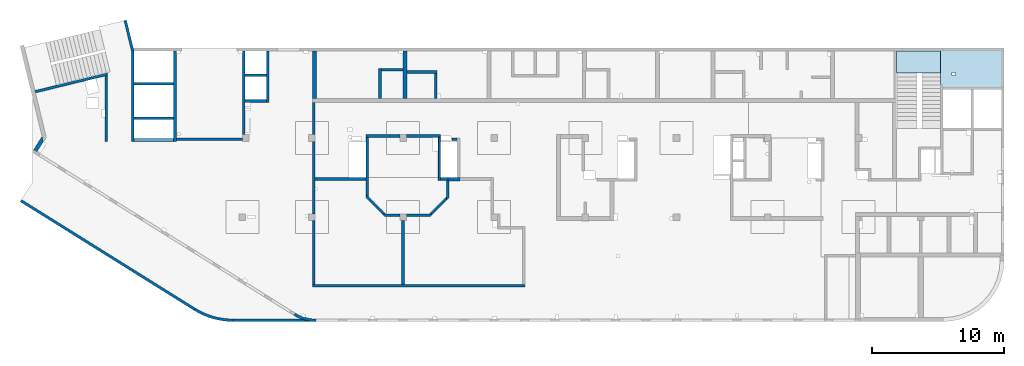
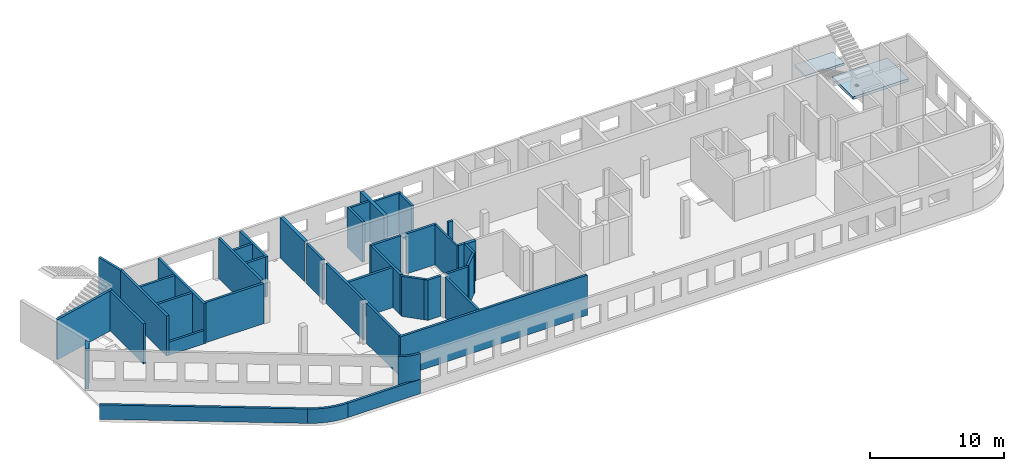
# One storey, part 3 of 10: 42 walls, 2 slabs.
"""IFC4 building model written with IfcOpenShell, lengths in millimetres."""

from ifc_helpers import new_model, entity, si_unit, converted_unit, derived_unit, direction, frame, origin, place, context, subcontext, project, spatial, indexed_curve, outline, extrude, material, type_object, element, save


model = new_model("IFC4")

# Units and contexts
model_context = context("Model", 3, precision=0.01, world=origin(), true_north=direction((6.12303176911189e-17, 1.0)))
plan_context = context("Plan", 3, precision=0.01, world=origin(), true_north=direction((6.12303176911189e-17, 1.0)))
body_context = subcontext(model_context, "Body", "Model", "MODEL_VIEW")
ifc_project = project(units=[si_unit("LENGTHUNIT", "METRE", prefix="MILLI"), si_unit("AREAUNIT", "SQUARE_METRE"), si_unit("VOLUMEUNIT", "CUBIC_METRE"), converted_unit("PLANEANGLEUNIT", "DEGREE", entity("IfcRatioMeasure", 0.0174532925199433), si_unit("PLANEANGLEUNIT", "RADIAN"), dimensions=[0, 0, 0, 0, 0, 0, 0]), si_unit("MASSUNIT", "GRAM", prefix="KILO"), derived_unit("MASSDENSITYUNIT", [(si_unit("MASSUNIT", "GRAM", prefix="KILO"), 1), (si_unit("LENGTHUNIT", "METRE"), -3)]), derived_unit("MOMENTOFINERTIAUNIT", [(si_unit("LENGTHUNIT", "METRE"), 4)]), si_unit("TIMEUNIT", "SECOND"), si_unit("FREQUENCYUNIT", "HERTZ"), si_unit("THERMODYNAMICTEMPERATUREUNIT", "DEGREE_CELSIUS"), derived_unit("THERMALTRANSMITTANCEUNIT", [(si_unit("MASSUNIT", "GRAM", prefix="KILO"), 1), (si_unit("THERMODYNAMICTEMPERATUREUNIT", "KELVIN"), -1), (si_unit("TIMEUNIT", "SECOND"), -3)]), derived_unit("VOLUMETRICFLOWRATEUNIT", [(si_unit("LENGTHUNIT", "METRE"), 3), (si_unit("TIMEUNIT", "SECOND"), -1)]), derived_unit("MASSFLOWRATEUNIT", [(si_unit("MASSUNIT", "GRAM", prefix="KILO"), 1), (si_unit("TIMEUNIT", "SECOND"), -1)]), derived_unit("ROTATIONALFREQUENCYUNIT", [(si_unit("TIMEUNIT", "SECOND"), -1)]), si_unit("ELECTRICCURRENTUNIT", "AMPERE"), si_unit("ELECTRICVOLTAGEUNIT", "VOLT"), si_unit("POWERUNIT", "WATT"), si_unit("FORCEUNIT", "NEWTON", prefix="KILO"), si_unit("ILLUMINANCEUNIT", "LUX"), si_unit("LUMINOUSFLUXUNIT", "LUMEN"), si_unit("LUMINOUSINTENSITYUNIT", "CANDELA"), derived_unit("USERDEFINED", [(si_unit("MASSUNIT", "GRAM", prefix="KILO"), -1), (si_unit("LENGTHUNIT", "METRE"), -2), (si_unit("TIMEUNIT", "SECOND"), 3), (si_unit("LUMINOUSFLUXUNIT", "LUMEN"), 1)]), derived_unit("LINEARVELOCITYUNIT", [(si_unit("LENGTHUNIT", "METRE"), 1), (si_unit("TIMEUNIT", "SECOND"), -1)]), si_unit("PRESSUREUNIT", "PASCAL"), derived_unit("USERDEFINED", [(si_unit("LENGTHUNIT", "METRE"), -2), (si_unit("MASSUNIT", "GRAM", prefix="KILO"), 1), (si_unit("TIMEUNIT", "SECOND"), -2)]), derived_unit("LINEARFORCEUNIT", [(si_unit("MASSUNIT", "GRAM", prefix="KILO"), 1), (si_unit("LENGTHUNIT", "METRE"), 1), (si_unit("TIMEUNIT", "SECOND"), -2), (si_unit("LENGTHUNIT", "METRE"), -1)]), derived_unit("PLANARFORCEUNIT", [(si_unit("MASSUNIT", "GRAM", prefix="KILO"), 1), (si_unit("LENGTHUNIT", "METRE"), 1), (si_unit("TIMEUNIT", "SECOND"), -2), (si_unit("LENGTHUNIT", "METRE"), -2)])], contexts=[model_context, plan_context])

# Site, building, storey
site_placement = place(None, origin())
site = spatial("IfcSite", under=ifc_project, at=site_placement, CompositionType="ELEMENT")
building_placement = place(site_placement, origin())
building = spatial("IfcBuilding", under=site, at=building_placement, CompositionType="ELEMENT")
storey_placement = place(building_placement, frame((0.0, 0.0, 4200.0)))
storey = spatial("IfcBuildingStorey", under=building, at=storey_placement, Name="02", CompositionType="ELEMENT", Elevation=4200.0)

# Slabs
ifc_material = material()
slab_type_1 = type_object("IfcSlabType", Name=":ADSK_ 25_250", PredefinedType="FLOOR", material=ifc_material)
placement = place(storey_placement, origin())
element("IfcSlab", 1, at=placement, inside=storey, type_object=slab_type_1, material=ifc_material, Name=":ADSK_ 25_250", ObjectType=":ADSK_ 25_250", PredefinedType="FLOOR", context=body_context, shape_type="SweptSolid", body=[
    extrude(outline(indexed_curve([(-1590.00000000001, -2374.99999999999), (-1390.00000000001, -2374.99999999999), (1539.99999999999, -2375.0), (1540.0, -2175.00000000001), (1540.00000000001, 2225.00000000001), (1540.00000000001, 2425.0), (-1589.99999999999, 2425.00000000001), (-1589.99999999999, 2225.00000000001), (-1590.00000000001, -2374.99999999999)], self_intersect=False), holes=[indexed_curve([(234.999999999561, -1250.00000000008), (484.999999999556, -1250.00000000008), (484.999999999556, -1500.00000000009), (234.999999999561, -1500.00000000009), (234.999999999561, -1250.00000000008)], self_intersect=False)]), frame((71145.0, 18910.0, -670.0), z_axis=(0.0, 0.0, 1.0), x_axis=(0.0, -1.0, 0.0)), (0.0, 0.0, 1.0), 250.0),
])
slab_type_2 = type_object("IfcSlabType", Name=":ADSK_ 25_200", PredefinedType="FLOOR", material=ifc_material)
element("IfcSlab", 2, at=placement, inside=storey, type_object=slab_type_2, material=ifc_material, Name=":ADSK_ 25_200", ObjectType=":ADSK_ 25_200", PredefinedType="FLOOR", context=body_context, shape_type="SweptSolid", body=[
    extrude(outline(indexed_curve([(-835.000000000001, -1670.00000000001), (834.999999999999, -1670.00000000001), (834.999999999999, 1670.00000000002), (-835.000000000001, 1670.00000000002), (-835.000000000001, -1670.00000000001)], self_intersect=False)), frame((67100.0, 19465.0, 1920.0), z_axis=(0.0, 0.0, -1.0), x_axis=(0.0, 1.0, 0.0)), (0.0, 0.0, 1.0), 200.0),
])

# Walls
wall_type_1 = type_object("IfcWallType", Name=":ADSK_ 25_200", PredefinedType="STANDARD")
wall_1_placement = place(storey_placement, frame((21465.0, -100.0, 0.0)))
element("IfcWall", 3, at=wall_1_placement, inside=storey, type_object=wall_type_1, material=ifc_material, Name=":ADSK_ 25_200", ObjectType=":ADSK_ 25_200", PredefinedType="NOTDEFINED", context=body_context, shape_type="SweptSolid", body=[
    extrude(outline(indexed_curve([(-1669.73115912917, 370.165232796526), (-1517.43719360754, 282.663604846569), (-1360.57165411762, 203.64974942406), (-1199.60712853313, 133.361711099216), (-1035.02855371873, 72.0112462252115), (-867.331754563609, 19.7831849810763), (-697.021950212787, -23.1651254650805), (-524.612231996435, -56.7042949949421), (-350.622017642682, -80.733280352823), (-175.575486430924, -95.1796895580798), (-5.19776222063229e-11, -100.0), (8.66293703438714e-12, 100.0), (-164.508224209949, 104.513888503701), (-328.521400565226, 118.041970555164), (-491.545970938351, 140.54353665169), (-653.091352173305, 171.950873752934), (-812.671412377304, 212.169469046979), (-969.805933817563, 261.078294363871), (-1124.02205802084, 318.530170380726), (-1274.85570872706, 384.352209522432), (-1421.85298841496, 458.346336225141), (-1564.57154419729, 540.289882996944), (-1669.73115912917, 370.165232796526)], self_intersect=False)), origin(), (0.0, 0.0, 1.0), 3500.0),
])
wall_2_placement = place(storey_placement, frame((-865.41, 8952.8, -150.0), z_axis=(0.0, 0.0, 1.0), x_axis=(0.848052743777572, -0.529911826412028, 0.0)))
element("IfcWall", 4, at=wall_2_placement, inside=storey, type_object=wall_type_1, material=ifc_material, Name=":ADSK_ 25_200", ObjectType=":ADSK_ 25_200", PredefinedType="NOTDEFINED", context=body_context, shape_type="SweptSolid", body=[
    extrude(outline(indexed_curve([(15506.5810864381, 100.0), (-1.03210773261253e-12, 100.0), (-1.94577687295805e-12, -99.9999999999995), (15506.5810864381, -99.9999999999989), (15506.5810864381, 100.0)], self_intersect=False)), origin(), (0.0, 0.0, 1.0), 1310.0),
])
wall_3_placement = place(storey_placement, frame((12284.99, 735.68, -150.0)))
element("IfcWall", 5, at=wall_3_placement, inside=storey, type_object=wall_type_1, material=ifc_material, Name=":ADSK_ 25_200", ObjectType=":ADSK_ 25_200", PredefinedType="NOTDEFINED", context=body_context, shape_type="SweptSolid", body=[
    extrude(outline(indexed_curve([(2915.01250070512, -735.684570137693), (2613.5342675926, -727.260252967498), (2312.99598516675, -702.024663872808), (2014.33436437137, -660.056456568838), (1718.48026701357, -601.486436618048), (1426.35580447471, -526.497153738303), (1138.87146369442, -435.322332836042), (856.923269385443, -328.246145537743), (581.389991323978, -205.602324490218), (313.130405419884, -67.7731231902071), (52.9806171032711, 84.8118754146881), (-52.9806171032429, -84.811875414706), (216.800382689777, -243.0458441733), (494.991419313605, -385.977729561331), (780.725433216402, -513.162044700461), (1073.11185506481, -624.202384384319), (1371.2393814503, -718.752660585296), (1674.17881521919, -796.518181133935), (1980.98596157331, -857.256568208814), (2290.7045709151, -900.778513774291), (2602.36931926479, -926.948369611523), (2915.00881696042, -935.684570103768), (2915.01250070512, -735.684570137693)], self_intersect=False)), origin(), (0.0, 0.0, 1.0), 1310.0),
])
wall_4_placement = place(storey_placement, frame((15200.0, -100.0, -150.0)))
element("IfcWall", 6, at=wall_4_placement, inside=storey, type_object=wall_type_1, material=ifc_material, Name=":ADSK_ 25_200", ObjectType=":ADSK_ 25_200", PredefinedType="NOTDEFINED", context=body_context, shape_type="SweptSolid", body=[
    extrude(outline(indexed_curve([(6264.99815812798, 100.0), (-3.14842759861503e-13, 100.0), (3.14842759861503e-13, -100.0), (6264.99815812798, -100.0), (6264.99815812798, 100.0)], self_intersect=False)), origin(), (0.0, 0.0, 1.0), 1310.0),
])
wall_5_placement = place(storey_placement, frame((220.24, 17202.38, -150.0), z_axis=(0.0, 0.0, 1.0), x_axis=(0.971552058141474, 0.236826092990334, 0.0)))
element("IfcWall", 7, at=wall_5_placement, inside=storey, type_object=wall_type_1, material=ifc_material, Name=":ADSK_ 25_200", ObjectType=":ADSK_ 25_200", PredefinedType="NOTDEFINED", context=body_context, shape_type="SweptSolid", body=[
    extrude(outline(indexed_curve([(5615.84117734387, -100.0), (5664.5932933022, 99.9999999999997), (3.13016279562817e-13, 99.9999999999999), (3.4262592762957e-13, -100.0), (5409.98499256816, -100.000000000001), (5615.84117734387, -100.0)], self_intersect=False)), origin(), (0.0, 0.0, 1.0), 3650.0),
])
wall_6_placement = place(storey_placement, frame((5600.0, 18435.2, -150.0), z_axis=(0.0, 0.0, 1.0), x_axis=(0.0, -1.0, 0.0)))
element("IfcWall", 8, at=wall_6_placement, inside=storey, type_object=wall_type_1, material=ifc_material, Name=":ADSK_ 25_200", ObjectType=":ADSK_ 25_200", PredefinedType="NOTDEFINED", context=body_context, shape_type="SweptSolid", body=[
    extrude(outline(indexed_curve([(4985.20145861122, -100.0), (4985.20145861122, 99.9999999999997), (-1.66881927142981e-13, 100.0), (48.7521159583304, -99.9999999999999), (2585.20145861117, -100.0), (3145.20145861117, -100.0), (4985.20145861122, -100.0)], self_intersect=False)), origin(), (0.0, 0.0, 1.0), 3650.0),
])
wall_7_placement = place(storey_placement, frame((7033.44, 22609.75, -150.0), z_axis=(0.0, 0.0, 1.0), x_axis=(0.236826092990336, -0.971552058141474, 0.0)))
element("IfcWall", 9, at=wall_7_placement, inside=storey, type_object=wall_type_1, material=ifc_material, Name=":ADSK_ 25_200", ObjectType=":ADSK_ 25_200", PredefinedType="NOTDEFINED", context=body_context, shape_type="SweptSolid", body=[
    extrude(outline(indexed_curve([(2380.28371765133, -100.0), (2404.30804833155, 99.9999999999996), (2401.76043829435, 99.9999999999994), (2195.90425351863, 99.9999999999995), (9.13669140345519e-13, 99.9999999999997), (-9.13669140345519e-13, -99.9999999999997), (2380.28371765133, -100.0)], self_intersect=False)), origin(), (0.0, 0.0, 1.0), 3650.0),
])
wall_8_placement = place(storey_placement, frame((7600.0, 13450.0, -150.0), z_axis=(0.0, 0.0, 1.0), x_axis=(0.0, 1.0, 0.0)))
element("IfcWall", 10, at=wall_8_placement, inside=storey, type_object=wall_type_1, material=ifc_material, Name=":ADSK_ 25_200", ObjectType=":ADSK_ 25_200", PredefinedType="NOTDEFINED", context=body_context, shape_type="SweptSolid", body=[
    extrude(outline(indexed_curve([(6847.52486422501, -99.9999999999998), (6823.50053354478, 100.0), (2.00396858490402e-12, 100.0), (1.61765673692763e-13, -100.0), (200.0, -99.9999999999997), (1649.99999999998, -99.9999999999995), (1849.99999999998, -100.0), (4249.99999999998, -99.9999999999996), (4449.99999999998, -100.0), (6847.52486422501, -99.9999999999998)], self_intersect=False)), origin(), (0.0, 0.0, 1.0), 3650.0),
])
wall_9_placement = place(storey_placement, frame((10800.0, 20300.0, -150.0), z_axis=(0.0, 0.0, 1.0), x_axis=(0.0, -1.0, 0.0)))
element("IfcWall", 11, at=wall_9_placement, inside=storey, type_object=wall_type_1, material=ifc_material, Name=":ADSK_ 25_200", ObjectType=":ADSK_ 25_200", PredefinedType="NOTDEFINED", context=body_context, shape_type="SweptSolid", body=[
    extrude(outline(indexed_curve([(6849.99999999999, 99.9999999999989), (-1.58082792598304e-13, 99.9999999999989), (1.58082792598304e-13, -99.9999999999989), (6849.99999999999, -99.9999999999989), (6849.99999999999, 99.9999999999989)], self_intersect=False)), origin(), (0.0, 0.0, 1.0), 3650.0),
])
for number, where, name in (
    (12, (7700.0, 15200.0, -150.0), ":ADSK_ 25_200"),
    (13, (7700.0, 17800.0, -150.0), ":ADSK_ 25_200"),
):
    element("IfcWall", number, at=place(storey_placement, frame(where)), inside=storey, type_object=wall_type_1, material=ifc_material, Name=name, ObjectType=":ADSK_ 25_200", PredefinedType="NOTDEFINED", context=body_context, shape_type="SweptSolid", body=[
        extrude(outline(indexed_curve([(3000.0, 99.9999999999989), (-2.88764567812901e-13, 99.9999999999989), (2.88764567812901e-13, -99.9999999999989), (3000.0, -99.9999999999989), (3000.0, 99.9999999999989)], self_intersect=False)), origin(), (0.0, 0.0, 1.0), 3650.0),
    ])
wall_10_placement = place(storey_placement, frame((10900.0, 13600.0, -150.0)))
element("IfcWall", 14, at=wall_10_placement, inside=storey, type_object=wall_type_1, material=ifc_material, Name=":ADSK_ 25_200", ObjectType=":ADSK_ 25_200", PredefinedType="NOTDEFINED", context=body_context, shape_type="SweptSolid", body=[
    extrude(outline(indexed_curve([(4999.99999999999, 99.9999999999989), (-3.03202796203547e-13, 99.9999999999989), (3.03202796203547e-13, -99.9999999999989), (4999.99999999999, -99.9999999999989), (4999.99999999999, 99.9999999999989)], self_intersect=False)), origin(), (0.0, 0.0, 1.0), 3650.0),
])
wall_11_placement = place(storey_placement, frame((16000.0, 13950.0, -150.0), z_axis=(0.0, 0.0, 1.0), x_axis=(0.0, 1.0, 0.0)))
element("IfcWall", 15, at=wall_11_placement, inside=storey, type_object=wall_type_1, material=ifc_material, Name=":ADSK_ 25_200", ObjectType=":ADSK_ 25_200", PredefinedType="NOTDEFINED", context=body_context, shape_type="SweptSolid", body=[
    extrude(outline(indexed_curve([(6350.00000000003, 99.999999999999), (-1.71883671317202e-13, 99.9999999999989), (1.71883671317202e-13, -99.9999999999989), (6350.00000000003, -99.9999999999988), (6350.00000000003, 99.999999999999)], self_intersect=False)), origin(), (0.0, 0.0, 1.0), 3650.0),
])
wall_12_placement = place(storey_placement, frame((17825.0, 20300.0, -150.0), z_axis=(0.0, 0.0, 1.0), x_axis=(0.0, -1.0, 0.0)))
element("IfcWall", 16, at=wall_12_placement, inside=storey, type_object=wall_type_1, material=ifc_material, Name=":ADSK_ 25_200", ObjectType=":ADSK_ 25_200", PredefinedType="NOTDEFINED", context=body_context, shape_type="SweptSolid", body=[
    extrude(outline(indexed_curve([(3900.00000000024, 99.9999999999989), (-1.66594942968972e-13, 99.9999999999989), (1.66594942968972e-13, -99.9999999999989), (3900.00000000024, -99.9999999999989), (3900.00000000024, 99.9999999999989)], self_intersect=False)), origin(), (0.0, 0.0, 1.0), 3650.0),
])
wall_13_placement = place(storey_placement, frame((17725.0, 16500.0, -150.0), z_axis=(0.0, 0.0, 1.0), x_axis=(-1.0, 0.0, 0.0)))
element("IfcWall", 17, at=wall_13_placement, inside=storey, type_object=wall_type_1, material=ifc_material, Name=":ADSK_ 25_200", ObjectType=":ADSK_ 25_200", PredefinedType="NOTDEFINED", context=body_context, shape_type="SweptSolid", body=[
    extrude(outline(indexed_curve([(1624.99999999998, 99.9999999999982), (-3.5601111100221e-13, 99.9999999999989), (3.5601111100221e-13, -99.9999999999989), (1624.99999999998, -99.9999999999996), (1624.99999999998, 99.9999999999982)], self_intersect=False)), origin(), (0.0, 0.0, 1.0), 3650.0),
])
wall_14_placement = place(storey_placement, frame((17725.0, 18450.0, -150.0), z_axis=(0.0, 0.0, 1.0), x_axis=(-1.0, 0.0, 0.0)))
element("IfcWall", 18, at=wall_14_placement, inside=storey, type_object=wall_type_1, material=ifc_material, Name=":ADSK_ 25_200", ObjectType=":ADSK_ 25_200", PredefinedType="NOTDEFINED", context=body_context, shape_type="SweptSolid", body=[
    extrude(outline(indexed_curve([(1624.99999999999, 99.9999999999986), (-3.77156646455302e-13, 99.9999999999989), (3.77156646455302e-13, -99.9999999999989), (1624.99999999999, -99.9999999999993), (1624.99999999999, 99.9999999999986)], self_intersect=False)), origin(), (0.0, 0.0, 1.0), 3650.0),
])
wall_15_placement = place(storey_placement, frame((21320.0, 13950.0, -150.0), z_axis=(0.0, 0.0, 1.0), x_axis=(0.0, 1.0, 0.0)))
element("IfcWall", 19, at=wall_15_placement, inside=storey, type_object=wall_type_1, material=ifc_material, Name=":ADSK_ 25_200", ObjectType=":ADSK_ 25_200", PredefinedType="NOTDEFINED", context=body_context, shape_type="SweptSolid", body=[
    extrude(outline(indexed_curve([(2449.99999999979, 99.9999999999994), (-1.96664178427031e-13, 99.9999999999989), (1.96664178427031e-13, -99.9999999999989), (2449.99999999979, -99.9999999999984), (2449.99999999979, 99.9999999999994)], self_intersect=False)), origin(), (0.0, 0.0, 1.0), 3650.0),
])
wall_16_placement = place(storey_placement, frame((21220.0, 2500.0, -150.0)))
element("IfcWall", 20, at=wall_16_placement, inside=storey, type_object=wall_type_1, material=ifc_material, Name=":ADSK_ 25_200", ObjectType=":ADSK_ 25_200", PredefinedType="NOTDEFINED", context=body_context, shape_type="SweptSolid", body=[
    extrude(outline(indexed_curve([(16075.0, 100.0), (-3.24719987565055e-13, 100.0), (3.24719987565054e-13, -99.9999999999997), (16075.0, -99.9999999999998), (16075.0, 100.0)], self_intersect=False)), origin(), (0.0, 0.0, 1.0), 3650.0),
])
wall_17_placement = place(storey_placement, frame((28070.0, 2600.0, -150.0), z_axis=(0.0, 0.0, 1.0), x_axis=(0.0, 1.0, 0.0)))
element("IfcWall", 21, at=wall_17_placement, inside=storey, type_object=wall_type_1, material=ifc_material, Name=":ADSK_ 25_200", ObjectType=":ADSK_ 25_200", PredefinedType="NOTDEFINED", context=body_context, shape_type="SweptSolid", body=[
    extrude(outline(indexed_curve([(4850.00000000007, 99.9999999999987), (-1.75008828977514e-13, 99.9999999999989), (1.75008828977514e-13, -99.9999999999989), (4850.00000000007, -99.9999999999991), (4850.00000000007, 99.9999999999987)], self_intersect=False)), origin(), (0.0, 0.0, 1.0), 3650.0),
])
wall_18_placement = place(storey_placement, frame((21320.0, 13450.0, -150.0), z_axis=(0.0, 0.0, 1.0), x_axis=(0.0, -1.0, 0.0)))
element("IfcWall", 22, at=wall_18_placement, inside=storey, type_object=wall_type_1, material=ifc_material, Name=":ADSK_ 25_200", ObjectType=":ADSK_ 25_200", PredefinedType="NOTDEFINED", context=body_context, shape_type="SweptSolid", body=[
    extrude(outline(indexed_curve([(5500.0, 99.9999999999989), (-1.57507946079764e-13, 99.9999999999989), (1.57507946079764e-13, -99.9999999999989), (5500.0, -99.9999999999989), (5500.0, 99.9999999999989)], self_intersect=False)), origin(), (0.0, 0.0, 1.0), 3650.0),
])
wall_19_placement = place(storey_placement, frame((21320.0, 7450.0, -150.0), z_axis=(0.0, 0.0, 1.0), x_axis=(0.0, -1.0, 0.0)))
element("IfcWall", 23, at=wall_19_placement, inside=storey, type_object=wall_type_1, material=ifc_material, Name=":ADSK_ 25_200", ObjectType=":ADSK_ 25_200", PredefinedType="NOTDEFINED", context=body_context, shape_type="SweptSolid", body=[
    extrude(outline(indexed_curve([(4850.00000000007, 99.9999999999989), (-1.78617258440967e-13, 99.9999999999989), (1.78617258440967e-13, -99.9999999999989), (4850.00000000007, -99.9999999999989), (4850.00000000007, 99.9999999999989)], self_intersect=False)), origin(), (0.0, 0.0, 1.0), 3650.0),
])
wall_20_placement = place(storey_placement, frame((32170.0, 13600.0, -150.0), z_axis=(0.0, 0.0, 1.0), x_axis=(-1.0, 0.0, 0.0)))
element("IfcWall", 24, at=wall_20_placement, inside=storey, type_object=wall_type_1, material=ifc_material, Name=":ADSK_ 25_200", ObjectType=":ADSK_ 25_200", PredefinedType="NOTDEFINED", context=body_context, shape_type="SweptSolid", body=[
    extrude(outline(indexed_curve([(399.999999999991, 99.9999999999982), (-3.60955709766133e-13, 99.9999999999989), (3.60955709766133e-13, -99.9999999999989), (399.999999999992, -99.9999999999996), (399.999999999991, 99.9999999999982)], self_intersect=False)), origin(), (0.0, 0.0, 1.0), 3650.0),
])
wall_21_placement = place(storey_placement, frame((31460.0, 10490.0, -150.0), z_axis=(0.0, 0.0, 1.0), x_axis=(0.0, -1.0, 0.0)))
element("IfcWall", 25, at=wall_21_placement, inside=storey, type_object=wall_type_1, material=ifc_material, Name=":ADSK_ 25_200", ObjectType=":ADSK_ 25_200", PredefinedType="NOTDEFINED", context=body_context, shape_type="SweptSolid", body=[
    extrude(outline(indexed_curve([(1517.84271247461, -100.000000000004), (1317.84271247462, 99.9999999999959), (65.0000000000382, 99.9999999999968), (65.0000000000372, -2.07407185169571e-12), (-4.33146851719343e-12, 4.33146851719371e-12), (-1.02514551324105e-12, -100.000000000003), (1235.0, -100.000000000004), (1517.84271247461, -100.000000000004)], self_intersect=False)), origin(), (0.0, 0.0, 1.0), 3650.0),
])
wall_22_placement = place(storey_placement, frame((28320.0, 7850.0, -150.0)))
element("IfcWall", 26, at=wall_22_placement, inside=storey, type_object=wall_type_1, material=ifc_material, Name=":ADSK_ 25_200", ObjectType=":ADSK_ 25_200", PredefinedType="NOTDEFINED", context=body_context, shape_type="SweptSolid", body=[
    extrude(outline(indexed_curve([(1817.84271247461, -99.9999999999999), (2017.84271247462, 99.9999999999996), (1735.0, 99.9999999999998), (-3.02005468313109e-13, 100.0), (3.02005468313109e-13, -100.0), (1817.84271247461, -99.9999999999999)], self_intersect=False)), origin(), (0.0, 0.0, 1.0), 3650.0),
])
wall_23_placement = place(storey_placement, frame((27820.0, 7850.0, -150.0), z_axis=(0.0, 0.0, 1.0), x_axis=(-1.0, 0.0, 0.0)))
element("IfcWall", 27, at=wall_23_placement, inside=storey, type_object=wall_type_1, material=ifc_material, Name=":ADSK_ 25_200", ObjectType=":ADSK_ 25_200", PredefinedType="NOTDEFINED", context=body_context, shape_type="SweptSolid", body=[
    extrude(outline(indexed_curve([(1347.84271247462, -99.9999999999998), (1147.84271247462, 100.0), (-4.9488612922406e-13, 100.0), (4.9488612922406e-13, -100.0), (1065.0, -100.0), (1347.84271247462, -99.9999999999998)], self_intersect=False)), origin(), (0.0, 0.0, 1.0), 3650.0),
])
wall_24_placement = place(storey_placement, frame((27820.0, 13850.0, -150.0), z_axis=(0.0, 0.0, 1.0), x_axis=(-1.0, 0.0, 0.0)))
element("IfcWall", 28, at=wall_24_placement, inside=storey, type_object=wall_type_1, material=ifc_material, Name=":ADSK_ 25_200", ObjectType=":ADSK_ 25_200", PredefinedType="NOTDEFINED", context=body_context, shape_type="SweptSolid", body=[
    extrude(outline(indexed_curve([(2570.00000000001, 99.9999999999988), (-3.32131638983616e-13, 99.9999999999989), (3.32131638983616e-13, -99.9999999999989), (2570.00000000001, -99.9999999999991), (2570.00000000001, 99.9999999999988)], self_intersect=False)), origin(), (0.0, 0.0, 1.0), 3650.0),
])
wall_25_placement = place(storey_placement, frame((25350.0, 13750.0, -150.0), z_axis=(0.0, 0.0, 1.0), x_axis=(0.0, -1.0, 0.0)))
element("IfcWall", 29, at=wall_25_placement, inside=storey, type_object=wall_type_1, material=ifc_material, Name=":ADSK_ 25_200", ObjectType=":ADSK_ 25_200", PredefinedType="NOTDEFINED", context=body_context, shape_type="SweptSolid", body=[
    extrude(outline(indexed_curve([(4295.0, -100.000000000003), (4495.00000000001, 99.9999999999989), (0.0, 99.9999999999989), (0.0, -100.000000000003), (3060.00000000004, -100.000000000003), (3260.00000000004, -100.000000000003), (4295.0, -100.000000000003)], self_intersect=False)), origin(), (0.0, 0.0, 1.0), 3650.0),
])
wall_26_placement = place(storey_placement, frame((28320.0, 13850.0, -150.0)))
element("IfcWall", 30, at=wall_26_placement, inside=storey, type_object=wall_type_1, material=ifc_material, Name=":ADSK_ 25_200", ObjectType=":ADSK_ 25_200", PredefinedType="NOTDEFINED", context=body_context, shape_type="SweptSolid", body=[
    extrude(outline(indexed_curve([(2580.0, 99.9999999999998), (-3.67626630400485e-13, 99.9999999999989), (3.67626630400485e-13, -99.9999999999989), (2580.0, -99.9999999999981), (2580.0, 99.9999999999998)], self_intersect=False)), origin(), (0.0, 0.0, 1.0), 3650.0),
])
wall_27_placement = place(storey_placement, frame((31460.0, 10590.0, -150.0), z_axis=(0.0, 0.0, 1.0), x_axis=(-1.0, 0.0, 0.0)))
element("IfcWall", 31, at=wall_27_placement, inside=storey, type_object=wall_type_1, material=ifc_material, Name=":ADSK_ 25_200", ObjectType=":ADSK_ 25_200", PredefinedType="NOTDEFINED", context=body_context, shape_type="SweptSolid", body=[
    extrude(outline(indexed_curve([(559.999999999966, 99.9999999999986), (-1.64731358047439e-12, 99.9999999999989), (1.64731358047439e-12, -99.9999999999989), (559.99999999997, -99.9999999999992), (559.999999999966, 99.9999999999986)], self_intersect=False)), origin(), (0.0, 0.0, 1.0), 3650.0),
])
wall_28_placement = place(storey_placement, frame((26684.29, 7879.29, -150.0), z_axis=(0.0, 0.0, 1.0), x_axis=(-0.707106781186546, 0.707106781186549, 0.0)))
element("IfcWall", 32, at=wall_28_placement, inside=storey, type_object=wall_type_1, material=ifc_material, Name=":ADSK_ 25_200", ObjectType=":ADSK_ 25_200", PredefinedType="NOTDEFINED", context=body_context, shape_type="SweptSolid", body=[
    extrude(outline(indexed_curve([(2128.39141137151, -100.000000000002), (1928.39141137151, 99.9999999999984), (200.000000000001, 99.9999999999979), (-1.32820421328006e-12, -100.000000000002), (1845.54869889689, -100.000000000002), (2128.39141137151, -100.000000000002)], self_intersect=False)), origin(), (0.0, 0.0, 1.0), 3650.0),
])
wall_29_placement = place(storey_placement, frame((25250.0, 10590.0, -150.0), z_axis=(0.0, 0.0, 1.0), x_axis=(-1.0, 0.0, 0.0)))
element("IfcWall", 33, at=wall_29_placement, inside=storey, type_object=wall_type_1, material=ifc_material, Name=":ADSK_ 25_200", ObjectType=":ADSK_ 25_200", PredefinedType="NOTDEFINED", context=body_context, shape_type="SweptSolid", body=[
    extrude(outline(indexed_curve([(3830.0, 100.000000000001), (-3.36454200178105e-13, 100.000000000001), (3.36454200178105e-13, -100.000000000001), (3830.0, -100.000000000001), (3830.0, 100.000000000001)], self_intersect=False)), origin(), (0.0, 0.0, 1.0), 3650.0),
])
wall_30_placement = place(storey_placement, frame((30125.71, 7879.29, -150.0), z_axis=(0.0, 0.0, 1.0), x_axis=(0.707106781186548, 0.707106781186547, 0.0)))
element("IfcWall", 34, at=wall_30_placement, inside=storey, type_object=wall_type_1, material=ifc_material, Name=":ADSK_ 25_200", ObjectType=":ADSK_ 25_200", PredefinedType="NOTDEFINED", context=body_context, shape_type="SweptSolid", body=[
    extrude(outline(indexed_curve([(1645.54869889691, -100.000000000003), (1845.5486988969, 99.9999999999981), (6.42952358020921e-13, 99.9999999999982), (200.000000000002, -100.000000000003), (1645.54869889691, -100.000000000003)], self_intersect=False)), origin(), (0.0, 0.0, 1.0), 3650.0),
])
wall_31_placement = place(storey_placement, frame((7700.0, 13550.0, -150.0)))
element("IfcWall", 35, at=wall_31_placement, inside=storey, type_object=wall_type_1, material=ifc_material, Name=":ADSK_ 25_200", ObjectType=":ADSK_ 25_200", PredefinedType="NOTDEFINED", context=body_context, shape_type="SweptSolid", body=[
    extrude(outline(indexed_curve([(3000.0, 99.9999999999989), (-2.88764567812901e-13, 99.9999999999989), (2.88764567812901e-13, -99.9999999999989), (3000.0, -99.9999999999989), (3000.0, 99.9999999999989)], self_intersect=False)), origin(), (0.0, 0.0, 1.0), 1200.0),
])
wall_32_placement = place(storey_placement, frame((26320.0, 16700.0, -150.0), z_axis=(0.0, 0.0, 1.0), x_axis=(0.0, 1.0, 0.0)))
element("IfcWall", 36, at=wall_32_placement, inside=storey, type_object=wall_type_1, material=ifc_material, Name=":ADSK_ 25_200", ObjectType=":ADSK_ 25_200", PredefinedType="NOTDEFINED", context=body_context, shape_type="SweptSolid", body=[
    extrude(outline(indexed_curve([(2280.0007736439, 99.9999999999993), (-2.08243601256231e-13, 99.9999999999989), (2.08243601256231e-13, -99.9999999999989), (2280.0007736439, -99.9999999999985), (2280.0007736439, 99.9999999999993)], self_intersect=False)), origin(), (0.0, 0.0, 1.0), 3650.0),
])
wall_33_placement = place(storey_placement, frame((26420.0, 18880.0, -150.0)))
element("IfcWall", 37, at=wall_33_placement, inside=storey, type_object=wall_type_1, material=ifc_material, Name=":ADSK_ 25_200", ObjectType=":ADSK_ 25_200", PredefinedType="NOTDEFINED", context=body_context, shape_type="SweptSolid", body=[
    extrude(outline(indexed_curve([(1650.00026855482, 99.9999999999989), (-2.62513200739495e-13, 99.9999999999989), (2.62513200739495e-13, -99.9999999999989), (1650.00026855482, -99.9999999999989), (1650.00026855482, 99.9999999999989)], self_intersect=False)), origin(), (0.0, 0.0, 1.0), 3650.0),
])
wall_34_placement = place(storey_placement, frame((28370.0, 18700.0, -150.0)))
element("IfcWall", 38, at=wall_34_placement, inside=storey, type_object=wall_type_1, material=ifc_material, Name=":ADSK_ 25_200", ObjectType=":ADSK_ 25_200", PredefinedType="NOTDEFINED", context=body_context, shape_type="SweptSolid", body=[
    extrude(outline(indexed_curve([(2279.99973144517, 99.9999999999995), (-3.12365558397263e-13, 99.9999999999989), (3.12365558397263e-13, -99.9999999999989), (2279.99973144517, -99.9999999999983), (2279.99973144517, 99.9999999999995)], self_intersect=False)), origin(), (0.0, 0.0, 1.0), 3650.0),
])
wall_35_placement = place(storey_placement, frame((30550.0, 18600.0, -150.0), z_axis=(0.0, 0.0, 1.0), x_axis=(0.0, -1.0, 0.0)))
element("IfcWall", 39, at=wall_35_placement, inside=storey, type_object=wall_type_1, material=ifc_material, Name=":ADSK_ 25_200", ObjectType=":ADSK_ 25_200", PredefinedType="NOTDEFINED", context=body_context, shape_type="SweptSolid", body=[
    extrude(outline(indexed_curve([(1900.0007736439, 99.9999999999989), (-2.27971934394871e-13, 99.9999999999989), (2.27971934394871e-13, -99.9999999999989), (1900.0007736439, -99.9999999999989), (1900.0007736439, 99.9999999999989)], self_intersect=False)), origin(), (0.0, 0.0, 1.0), 3650.0),
])
wall_type_2 = type_object("IfcWallType", Name=":ADSK_ 25_300", PredefinedType="STANDARD")
wall_36_placement = place(storey_placement, frame((233.4, 12729.37, -150.0), z_axis=(0.0, 0.0, 1.0), x_axis=(0.529911826412026, 0.848052743777573, 0.0)))
element("IfcWall", 40, at=wall_36_placement, inside=storey, type_object=wall_type_2, material=ifc_material, Name=":ADSK_ 25_300", ObjectType=":ADSK_ 25_300", PredefinedType="NOTDEFINED", context=body_context, shape_type="SweptSolid", body=[
    extrude(outline(indexed_curve([(896.727593512352, -150.000000000001), (1189.49773437786, 149.999999999999), (2.36031194589259e-12, 149.999999999999), (-7.1063155360207e-13, -150.000000000001), (896.727593512352, -150.000000000001)], self_intersect=False)), origin(), (0.0, 0.0, 1.0), 3650.0),
])
wall_37_placement = place(storey_placement, frame((21370.0, 16700.0, -150.0), z_axis=(0.0, 0.0, 1.0), x_axis=(0.0, 1.0, 0.0)))
element("IfcWall", 41, at=wall_37_placement, inside=storey, type_object=wall_type_2, material=ifc_material, Name=":ADSK_ 25_300", ObjectType=":ADSK_ 25_300", PredefinedType="NOTDEFINED", context=body_context, shape_type="SweptSolid", body=[
    extrude(outline(indexed_curve([(3600.00000000024, 150.0), (-3.27232685993138e-13, 150.000000000001), (3.27232685993138e-13, -150.000000000001), (3600.00000000024, -150.000000000001), (3600.00000000024, 150.0)], self_intersect=False)), origin(), (0.0, 0.0, 1.0), 3650.0),
])
wall_38_placement = place(storey_placement, frame((28220.0, 20300.0, -150.0), z_axis=(0.0, 0.0, 1.0), x_axis=(0.0, -1.0, 0.0)))
element("IfcWall", 42, at=wall_38_placement, inside=storey, type_object=wall_type_2, material=ifc_material, Name=":ADSK_ 25_300", ObjectType=":ADSK_ 25_300", PredefinedType="NOTDEFINED", context=body_context, shape_type="SweptSolid", body=[
    extrude(outline(indexed_curve([(3600.00000000024, 150.000000000001), (-1.806020255871e-13, 150.000000000001), (1.806020255871e-13, -150.000000000001), (3600.00000000024, -150.000000000001), (3600.00000000024, 150.000000000001)], self_intersect=False)), origin(), (0.0, 0.0, 1.0), 3600.0),
])
wall_type_3 = type_object("IfcWallType", Name=":ADSK_ 25_265", PredefinedType="STANDARD")
wall_39_placement = place(storey_placement, frame((32370.0, 10557.5, -150.0), z_axis=(0.0, 0.0, 1.0), x_axis=(-1.0, 0.0, 0.0)))
element("IfcWall", 43, at=wall_39_placement, inside=storey, type_object=wall_type_3, material=ifc_material, Name=":ADSK_ 25_265", ObjectType=":ADSK_ 25_265", PredefinedType="NOTDEFINED", context=body_context, shape_type="SweptSolid", body=[
    extrude(outline(indexed_curve([(910.000000000044, 132.5), (-2.41191922680361e-13, 132.5), (2.41191922680361e-13, -132.5), (910.000000000045, -132.5), (910.000000000044, 132.5)], self_intersect=False)), origin(), (0.0, 0.0, 1.0), 3650.0),
])
wall_type_4 = type_object("IfcWallType", Name=":ADSK_ 25_150", PredefinedType="STANDARD")
wall_40_placement = place(storey_placement, frame((30825.0, 13750.0, -150.0), z_axis=(0.0, 0.0, 1.0), x_axis=(0.0, -1.0, 0.0)))
element("IfcWall", 44, at=wall_40_placement, inside=storey, type_object=wall_type_4, material=ifc_material, Name=":ADSK_ 25_150", ObjectType=":ADSK_ 25_150", PredefinedType="NOTDEFINED", context=body_context, shape_type="SweptSolid", body=[
    extrude(outline(indexed_curve([(3260.00000000004, 75.0000000000003), (0.0, 75.0000000000003), (0.0, -75.0000000000003), (3260.00000000004, -75.0000000000003), (3260.00000000004, 75.0000000000003)], self_intersect=False)), origin(), (0.0, 0.0, 1.0), 3650.0),
])

save(model, "model.ifc")
